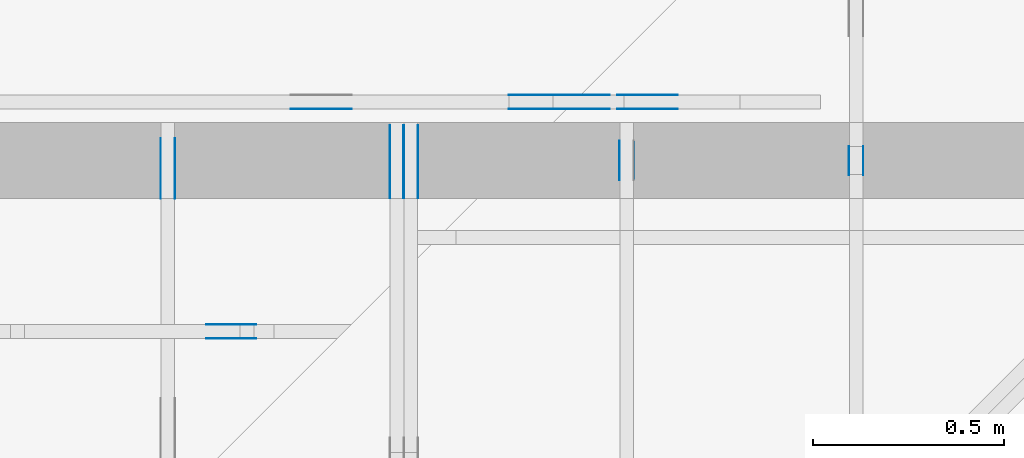
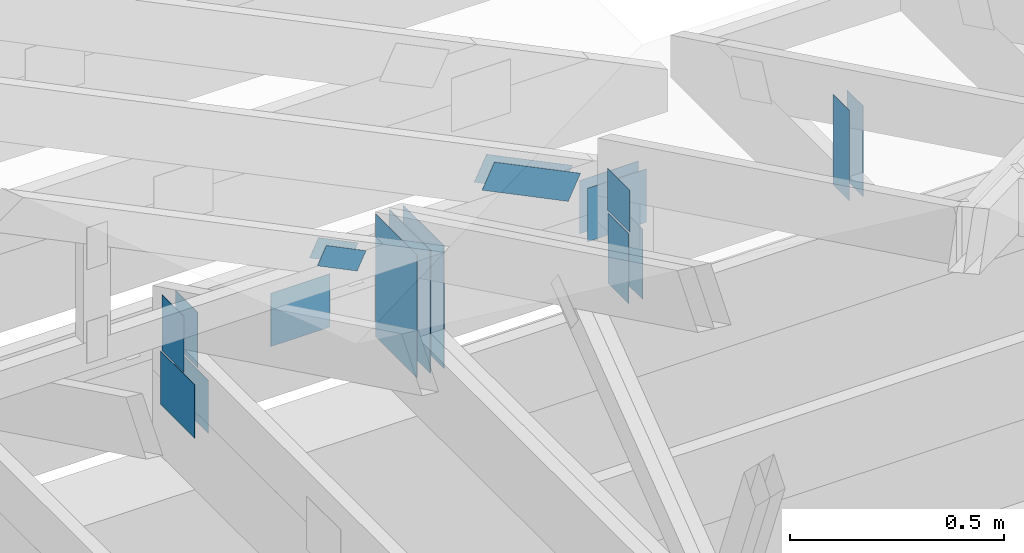
# One storey, part 131 of 159: 20 plates, 6 elements without a shape of their own.
"""IFC2X3 building model written with IfcOpenShell, lengths in millimetres."""

from ifc_helpers import new_model, si_unit, frame, origin, origin_with_axes, origin_2d, place, context, project, spatial, faceted_brep, element, aggregate, save


model = new_model("IFC2X3")

# Units and contexts
model_context = context("Model", 3, precision=1e-05, world=origin())
plan_context = context("Plan", 2, precision=1e-05, world=origin_2d())
ifc_project = project(units=[si_unit("LENGTHUNIT", "METRE", prefix="MILLI"), si_unit("AREAUNIT", "SQUARE_METRE"), si_unit("VOLUMEUNIT", "CUBIC_METRE"), si_unit("SOLIDANGLEUNIT", "STERADIAN"), si_unit("PLANEANGLEUNIT", "RADIAN"), si_unit("MASSUNIT", "GRAM"), si_unit("TIMEUNIT", "SECOND"), si_unit("THERMODYNAMICTEMPERATUREUNIT", "DEGREE_CELSIUS"), si_unit("LUMINOUSINTENSITYUNIT", "LUMEN")], contexts=[model_context, plan_context])

# Site, building, storey
site_placement = place(None, origin_with_axes())
site = spatial("IfcSite", under=ifc_project, at=site_placement, CompositionType="ELEMENT")
building_placement = place(site_placement, origin_with_axes())
building = spatial("IfcBuilding", under=site, at=building_placement, Name="Plan 1", CompositionType="ELEMENT")
storey_placement = place(building_placement, origin_with_axes())
storey = spatial("IfcBuildingStorey", under=building, at=storey_placement, Name="Etasje 1", CompositionType="ELEMENT", Elevation=0.0)

# Assembly, plates
assembly_1_placement = place(storey_placement, frame((10000.012663278096, 9072.000080051337, 1.1021457184401395e-15), z_axis=(9.811600543477555e-09, 1.0, 6.123031769111886e-17), x_axis=(-1.0, 9.811600543477555e-09, 0.0)))
assembly_1 = element("IfcElementAssembly", 1, at=assembly_1_placement, inside=storey, Name="T9 (79)", AssemblyPlace="FACTORY", PredefinedType="TRUSS")
plate_1_placement = place(assembly_1_placement, frame((-8826.91796875, 147.0, 0.0), z_axis=(0.0, 0.0, 1.0), x_axis=(1.0, 0.0, 0.0)))
plate_1 = element("IfcPlate", 2, at=plate_1_placement, Name="GNT100S 152x159", context=model_context, shape_type="Brep", body=[
    faceted_brep([(159.0, 152.0, 1.0), (0.0, 152.0, 1.0), (0.0, 0.0, 1.0), (159.0, 0.0, 1.0), (0.0, 152.0, 0.0), (159.0, 152.0, 1.9471241025775798e-14), (159.0, 0.0, 1.9471241025775798e-14), (0.0, 0.0, 0.0), (159.00041615731425, -2.920693798299738e-14, 1.788350091483736e-30), (159.00041615731425, -2.9145707665306264e-14, 1.0), (0.00041615731424826663, 6.115387335743615e-17, 1.0), (0.00041615731424826663, -7.644433368271246e-20, 4.680710837078382e-36), (159.00041615731425, 152.0, 0.0), (159.00041615731425, 152.0, 1.0), (159.00041615731425, 0.0, 1.0), (159.00041615731425, 0.0, 0.0), (0.00041615731424826663, 152.0, 0.0), (0.00041615731424826663, 152.0, 1.0), (159.00041615731425, 152.0, 1.0), (159.00041615731425, 152.0, 0.0), (0.00041615731424826663, 0.0, 0.0), (0.0004161573142483279, -7.498303609110687e-33, 1.0), (0.0004161573142669419, 152.0, 1.0), (0.00041615731426688065, 152.0, -1.1397412669640613e-30)], [[[0, 1, 2, 3]], [[4, 5, 6, 7]], [[8, 9, 10, 11]], [[12, 13, 14, 15]], [[16, 17, 18, 19]], [[20, 21, 22, 23]]]),
])
plate_2_placement = place(assembly_1_placement, frame((-8826.91796875, 147.0, -37.0), z_axis=(0.0, 0.0, 1.0), x_axis=(1.0, 0.0, 0.0)))
plate_2 = element("IfcPlate", 3, at=plate_2_placement, Name="GNT100S 152x159", context=model_context, shape_type="Brep", body=[
    faceted_brep([(159.0, 152.0, 1.0), (0.0, 152.0, 1.0), (0.0, 0.0, 1.0), (159.0, 0.0, 1.0), (0.0, 152.0, 0.0), (159.0, 152.0, 1.9471241025775798e-14), (159.0, 0.0, 1.9471241025775798e-14), (0.0, 0.0, 0.0), (159.00041615731425, -2.920693798299738e-14, 1.788350091483736e-30), (159.00041615731425, -2.9145707665306264e-14, 1.0), (0.00041615731424826663, 6.115387335743615e-17, 1.0), (0.00041615731424826663, -7.644433368271246e-20, 4.680710837078382e-36), (159.00041615731425, 152.0, 0.0), (159.00041615731425, 152.0, 1.0), (159.00041615731425, 0.0, 1.0), (159.00041615731425, 0.0, 0.0), (0.00041615731424826663, 152.0, 0.0), (0.00041615731424826663, 152.0, 1.0), (159.00041615731425, 152.0, 1.0), (159.00041615731425, 152.0, 0.0), (0.00041615731424826663, 0.0, 0.0), (0.0004161573142483279, -7.498303609110687e-33, 1.0), (0.0004161573142669419, 152.0, 1.0), (0.00041615731426688065, 152.0, -1.1397412669640613e-30)], [[[0, 1, 2, 3]], [[4, 5, 6, 7]], [[8, 9, 10, 11]], [[12, 13, 14, 15]], [[16, 17, 18, 19]], [[20, 21, 22, 23]]]),
])
plate_3_placement = place(assembly_1_placement, frame((-7973.47314453125, 147.0, -37.0), z_axis=(0.0, 0.0, 1.0), x_axis=(1.0, 0.0, 0.0)))
plate_3 = element("IfcPlate", 4, at=plate_3_placement, Name="GNT100S 152x159", context=model_context, shape_type="Brep", body=[
    faceted_brep([(159.0, 152.0, 1.0), (0.0, 152.0, 1.0), (0.0, 0.0, 1.0), (159.0, 0.0, 1.0), (0.0, 152.0, 0.0), (159.0, 152.0, 1.9471241025775798e-14), (159.0, 0.0, 1.9471241025775798e-14), (0.0, 0.0, 0.0), (159.00006797736023, -2.9206874025489785e-14, 1.7883461753452272e-30), (159.00006797736023, -2.9145643707798666e-14, 1.0), (6.797736023145262e-05, 6.121783086503054e-17, 1.0), (6.797736023145262e-05, -1.248682608832642e-20, 7.645723283419777e-37), (159.00006797736023, 152.0, 0.0), (159.00006797736023, 152.0, 1.0), (159.00006797736023, 0.0, 1.0), (159.00006797736023, 0.0, 0.0), (6.797736023145262e-05, 152.0, 0.0), (6.797736023145262e-05, 152.0, 1.0), (159.00006797736023, 152.0, 1.0), (159.00006797736023, 152.0, 0.0), (6.797736023145262e-05, 0.0, 0.0), (6.797736023151385e-05, -7.498303609110687e-33, 1.0), (6.797736025012787e-05, 152.0, 1.0), (6.797736025006664e-05, 152.0, -1.1397420192804459e-30)], [[[0, 1, 2, 3]], [[4, 5, 6, 7]], [[8, 9, 10, 11]], [[12, 13, 14, 15]], [[16, 17, 18, 19]], [[20, 21, 22, 23]]]),
])
plate_4_placement = place(assembly_1_placement, frame((-8615.85361649331, 280.2957601707253, 0.0), z_axis=(0.0, 0.0, 1.0), x_axis=(0.8987940462991671, 0.438371146789077, 0.0)))
plate_4 = element("IfcPlate", 5, at=plate_4_placement, Name="GNT100S 76x258", context=model_context, shape_type="Brep", body=[
    faceted_brep([(258.0006943892495, 76.00022406976359, 1.0), (0.0, 76.00022406976359, 1.0), (0.00017802805359679041, 0.00013491363233697484, 1.0), (257.99999468874194, 0.00013491363233697484, 1.0), (0.0, 76.00022406976359, 0.0), (258.0006943892495, 76.00022406976359, 3.1594928963966024e-14), (257.99999468874194, 0.00019715747384907445, 3.1594843278197295e-14), (0.00017802805359679041, 0.00019715747384907445, 2.1801428559326026e-20), (258.0004291662817, -5.094506431539717e-14, 3.119382472826252e-30), (258.0004291662817, -5.0883833997706053e-14, 1.0), (0.00042916628262901213, 4.548084964604827e-13, 1.0), (0.00042916628262901213, 4.5474726614279163e-13, 5.188881990034325e-36), (258.0004291662817, 76.00000000000045, -5.679798517591285e-29), (258.0004291662817, 76.00000000000045, 1.0), (258.0004291662817, 0.0, 1.0), (258.0004291662817, 0.0, 0.0), (0.00042916628262901213, 75.99999999999955, 0.0), (0.00042916628262901213, 75.99999999999955, 1.0), (258.00042916628263, 76.00000000000044, 1.0), (258.00042916628263, 76.00000000000044, 0.0), (0.00042916628262901213, 4.547473508864641e-13, 0.0), (0.0004291662826290734, 4.547473508864641e-13, 1.0), (0.00042916628263838034, 75.99999999999955, 1.0), (0.00042916628263831914, 75.99999999999955, -5.698706334820307e-31)], [[[0, 1, 2, 3]], [[4, 5, 6, 7]], [[8, 9, 10, 11]], [[12, 13, 14, 15]], [[16, 17, 18, 19]], [[20, 21, 22, 23]]]),
])
plate_5_placement = place(assembly_1_placement, frame((-8615.85361649331, 280.2957601707253, -36.99999999999999), z_axis=(0.0, 0.0, 1.0), x_axis=(0.8987940462991671, 0.438371146789077, 0.0)))
plate_5 = element("IfcPlate", 6, at=plate_5_placement, Name="GNT100S 76x258", context=model_context, shape_type="Brep", body=[
    faceted_brep([(258.0006943892495, 76.00022406976359, 1.0), (0.0, 76.00022406976359, 1.0), (0.00017802805359679041, 0.00013491363233697484, 1.0), (257.99999468874194, 0.00013491363233697484, 1.0), (0.0, 76.00022406976359, 0.0), (258.0006943892495, 76.00022406976359, 3.1594928963966024e-14), (257.99999468874194, 0.00019715747384907445, 3.1594843278197295e-14), (0.00017802805359679041, 0.00019715747384907445, 2.1801428559326026e-20), (258.0004291662817, -5.094506431539717e-14, 3.119382472826252e-30), (258.0004291662817, -5.0883833997706053e-14, 1.0), (0.00042916628262901213, 4.548084964604827e-13, 1.0), (0.00042916628262901213, 4.5474726614279163e-13, 5.188881990034325e-36), (258.0004291662817, 76.00000000000045, -5.679798517591285e-29), (258.0004291662817, 76.00000000000045, 1.0), (258.0004291662817, 0.0, 1.0), (258.0004291662817, 0.0, 0.0), (0.00042916628262901213, 75.99999999999955, 0.0), (0.00042916628262901213, 75.99999999999955, 1.0), (258.00042916628263, 76.00000000000044, 1.0), (258.00042916628263, 76.00000000000044, 0.0), (0.00042916628262901213, 4.547473508864641e-13, 0.0), (0.0004291662826290734, 4.547473508864641e-13, 1.0), (0.00042916628263838034, 75.99999999999955, 1.0), (0.00042916628263831914, 75.99999999999955, -5.698706334820307e-31)], [[[0, 1, 2, 3]], [[4, 5, 6, 7]], [[8, 9, 10, 11]], [[12, 13, 14, 15]], [[16, 17, 18, 19]], [[20, 21, 22, 23]]]),
])
aggregate(assembly_1, [plate_1, plate_2, plate_3, plate_4, plate_5])

assembly_2_placement = place(storey_placement, frame((18074.541652722903, -699.9989301294845, 4.408582873760558e-15), z_axis=(-1.0, 1.836909530733566e-16, 6.123031769111886e-17), x_axis=(-1.836909530733566e-16, -1.0, 0.0)))
assembly_2 = element("IfcElementAssembly", 7, at=assembly_2_placement, inside=storey, Name="V5 (30)", AssemblyPlace="FACTORY", PredefinedType="TRUSS")
plate_6_placement = place(assembly_2_placement, frame((-9501.99892397318, 109.01662445068358, 0.0), z_axis=(0.0, 0.0, 1.0), x_axis=(6.123031769111886e-17, 1.0, 0.0)))
plate_6 = element("IfcPlate", 8, at=plate_6_placement, context=model_context, shape_type="Brep", body=[
    faceted_brep([(350.00000762939453, 192.00009946431965, 1.3), (0.0, 192.00009946431965, 1.3), (1.4210854715202004e-14, 9.946431964635849e-05, 1.3), (350.00000762939453, 9.946431964635849e-05, 1.3), (0.0, 192.00009946431965, 0.0), (350.00000762939453, 192.00009946431965, 4.2861223318083706e-14), (350.00000762939453, 9.946431964635849e-05, 4.2861223318083706e-14), (1.4210854715202004e-14, 9.946431964635849e-05, 1.7402702977483063e-30), (350.0000025879075, -6.429183405105e-14, 3.936609423890485e-30), (350.0000025879075, -6.421223463805154e-14, 1.3), (2.5879074883050635e-06, 7.959893762326153e-17, 1.3), (2.5879074883050635e-06, -4.753751929924335e-22, 2.9107374089403646e-38), (350.0000025879075, 192.0, 0.0), (350.0000025879075, 192.0, 1.3), (350.0000025879075, 0.0, 1.3), (350.0000025879075, 0.0, 0.0), (2.5879074883050635e-06, 192.0, 0.0), (2.5879074883050635e-06, 192.0, 1.3), (350.0000025879075, 191.99999999999997, 1.3), (350.0000025879075, 191.99999999999997, -1.5777218104420236e-30), (2.5879074883050635e-06, 0.0, 0.0), (2.587907488384663e-06, -9.747794691843893e-33, 1.3), (2.587907511897105e-06, 192.0, 1.3), (2.5879075118175054e-06, 192.0, -1.439674292949252e-30)], [[[0, 1, 2, 3]], [[4, 5, 6, 7]], [[8, 9, 10, 11]], [[12, 13, 14, 15]], [[16, 17, 18, 19]], [[20, 21, 22, 23]]]),
])
plate_7_placement = place(assembly_2_placement, frame((-9501.99892397318, 109.01662445068358, -37.3), z_axis=(0.0, 0.0, 1.0), x_axis=(6.123031769111886e-17, 1.0, 0.0)))
plate_7 = element("IfcPlate", 9, at=plate_7_placement, context=model_context, shape_type="Brep", body=[
    faceted_brep([(350.00000762939453, 192.00009946431965, 1.2999999999999972), (0.0, 192.00009946431965, 1.2999999999999972), (1.4210854715202004e-14, 9.946431964635849e-05, 1.2999999999999972), (350.00000762939453, 9.946431964635849e-05, 1.2999999999999972), (0.0, 192.00009946431965, 0.0), (350.00000762939453, 192.00009946431965, 4.2861223318083706e-14), (350.00000762939453, 9.946431964635849e-05, 4.2861223318083706e-14), (1.4210854715202004e-14, 9.946431964635849e-05, 1.7402702977483063e-30), (350.0000025879075, -6.429183405105e-14, 3.936609423890485e-30), (350.0000025879075, -6.421223463805154e-14, 1.2999999999999972), (2.5879074883050635e-06, 7.959893762326135e-17, 1.2999999999999972), (2.5879074883050635e-06, -4.753751929924335e-22, 2.9107374089403646e-38), (350.0000025879075, 192.0, 0.0), (350.0000025879075, 192.0, 1.2999999999999972), (350.0000025879075, 0.0, 1.2999999999999972), (350.0000025879075, 0.0, 0.0), (2.5879074883050635e-06, 192.0, 0.0), (2.5879074883050635e-06, 192.0, 1.2999999999999972), (350.0000025879075, 191.99999999999997, 1.2999999999999972), (350.0000025879075, 191.99999999999997, -1.5777218104420236e-30), (2.5879074883050635e-06, 0.0, 0.0), (2.587907488384663e-06, -9.747794691843873e-33, 1.2999999999999972), (2.587907511897105e-06, 192.0, 1.2999999999999972), (2.5879075118175054e-06, 192.0, -1.439674292949252e-30)], [[[0, 1, 2, 3]], [[4, 5, 6, 7]], [[8, 9, 10, 11]], [[12, 13, 14, 15]], [[16, 17, 18, 19]], [[20, 21, 22, 23]]]),
])
plate_8_placement = place(assembly_2_placement, frame((-9501.99892397318, 109.01662445068358, -36.0), z_axis=(0.0, 0.0, 1.0), x_axis=(6.123031769111886e-17, 1.0, 0.0)))
plate_8 = element("IfcPlate", 10, at=plate_8_placement, context=model_context, shape_type="Brep", body=[
    faceted_brep([(350.00000762939453, 192.00009946431965, 1.2999999999999972), (0.0, 192.00009946431965, 1.2999999999999972), (1.4210854715202004e-14, 9.946431964635849e-05, 1.2999999999999972), (350.00000762939453, 9.946431964635849e-05, 1.2999999999999972), (0.0, 192.00009946431965, 0.0), (350.00000762939453, 192.00009946431965, 4.2861223318083706e-14), (350.00000762939453, 9.946431964635849e-05, 4.2861223318083706e-14), (1.4210854715202004e-14, 9.946431964635849e-05, 1.7402702977483063e-30), (350.0000025879075, -6.429183405105e-14, 3.936609423890485e-30), (350.0000025879075, -6.421223463805154e-14, 1.2999999999999972), (2.5879074883050635e-06, 7.959893762326135e-17, 1.2999999999999972), (2.5879074883050635e-06, -4.753751929924335e-22, 2.9107374089403646e-38), (350.0000025879075, 192.0, 0.0), (350.0000025879075, 192.0, 1.2999999999999972), (350.0000025879075, 0.0, 1.2999999999999972), (350.0000025879075, 0.0, 0.0), (2.5879074883050635e-06, 192.0, 0.0), (2.5879074883050635e-06, 192.0, 1.2999999999999972), (350.0000025879075, 191.99999999999997, 1.2999999999999972), (350.0000025879075, 191.99999999999997, -1.5777218104420236e-30), (2.5879074883050635e-06, 0.0, 0.0), (2.587907488384663e-06, -9.747794691843873e-33, 1.2999999999999972), (2.587907511897105e-06, 192.0, 1.2999999999999972), (2.5879075118175054e-06, 192.0, -1.439674292949252e-30)], [[[0, 1, 2, 3]], [[4, 5, 6, 7]], [[8, 9, 10, 11]], [[12, 13, 14, 15]], [[16, 17, 18, 19]], [[20, 21, 22, 23]]]),
])
plate_9_placement = place(assembly_2_placement, frame((-9501.99892397318, 109.01662445068358, -73.3), z_axis=(0.0, 0.0, 1.0), x_axis=(6.123031769111886e-17, 1.0, 0.0)))
plate_9 = element("IfcPlate", 11, at=plate_9_placement, context=model_context, shape_type="Brep", body=[
    faceted_brep([(350.00000762939453, 192.00009946431965, 1.2999999999999972), (0.0, 192.00009946431965, 1.2999999999999972), (1.4210854715202004e-14, 9.946431964635849e-05, 1.2999999999999972), (350.00000762939453, 9.946431964635849e-05, 1.2999999999999972), (0.0, 192.00009946431965, 0.0), (350.00000762939453, 192.00009946431965, 4.2861223318083706e-14), (350.00000762939453, 9.946431964635849e-05, 4.2861223318083706e-14), (1.4210854715202004e-14, 9.946431964635849e-05, 1.7402702977483063e-30), (350.0000025879075, -6.429183405105e-14, 3.936609423890485e-30), (350.0000025879075, -6.421223463805154e-14, 1.2999999999999972), (2.5879074883050635e-06, 7.959893762326135e-17, 1.2999999999999972), (2.5879074883050635e-06, -4.753751929924335e-22, 2.9107374089403646e-38), (350.0000025879075, 192.0, 0.0), (350.0000025879075, 192.0, 1.2999999999999972), (350.0000025879075, 0.0, 1.2999999999999972), (350.0000025879075, 0.0, 0.0), (2.5879074883050635e-06, 192.0, 0.0), (2.5879074883050635e-06, 192.0, 1.2999999999999972), (350.0000025879075, 191.99999999999997, 1.2999999999999972), (350.0000025879075, 191.99999999999997, -1.5777218104420236e-30), (2.5879074883050635e-06, 0.0, 0.0), (2.587907488384663e-06, -9.747794691843873e-33, 1.2999999999999972), (2.587907511897105e-06, 192.0, 1.2999999999999972), (2.5879075118175054e-06, 192.0, -1.439674292949252e-30)], [[[0, 1, 2, 3]], [[4, 5, 6, 7]], [[8, 9, 10, 11]], [[12, 13, 14, 15]], [[16, 17, 18, 19]], [[20, 21, 22, 23]]]),
])
aggregate(assembly_2, [plate_6, plate_7, plate_8, plate_9])

assembly_3_placement = place(storey_placement, frame((17475.02226140475, -699.9989301294827, 1.1021457184401395e-15), z_axis=(-1.0, 1.836909530733566e-16, 6.123031769111886e-17), x_axis=(-1.836909530733566e-16, -1.0, 0.0)))
assembly_3 = element("IfcElementAssembly", 12, at=assembly_3_placement, inside=storey, Name="V6 (31)", AssemblyPlace="FACTORY", PredefinedType="TRUSS")
plate_10_placement = place(assembly_3_placement, frame((-9551.357421875, 304.17950439453125, 0.0), z_axis=(0.0, 0.0, 1.0), x_axis=(6.123031769111886e-17, 1.0, 0.0)))
plate_10 = element("IfcPlate", 13, at=plate_10_placement, Name="GNT100S 103x159", context=model_context, shape_type="Brep", body=[
    faceted_brep([(159.0, 103.0, 1.0), (0.0, 103.0, 1.0), (0.0, 0.0, 1.0), (159.0, 0.0, 1.0), (0.0, 103.0, 0.0), (159.0, 103.0, 1.9471241025775798e-14), (159.0, 0.0, 1.9471241025775798e-14), (0.0, 0.0, 0.0), (159.0, 0.00015826327032108267, 1.7883448193523036e-30), (159.0, 0.0001582632703211439, 1.0), (1.1247455413666031e-32, 0.00015826327035035076, 1.0), (0.0, 0.00015826327035028953, 0.0), (159.0, 103.00015826327035, 0.0), (159.0, 103.00015826327035, 1.0), (159.0, 0.00015826327035028953, 1.0), (159.0, 0.00015826327035028953, 0.0), (0.0, 103.00015826327035, 0.0), (-3.7491518045553436e-33, 103.00015826327035, 1.0), (159.0, 103.00015826327034, 1.0), (159.0, 103.00015826327034, -7.888609052210118e-31), (1.938102064476732e-20, 0.00015826327035028953, -1.1867060512572364e-36), (6.124969871176363e-17, 0.00015826327035028953, 1.0), (1.267469514308225e-14, 103.00015826327035, 1.0), (1.2613464825391131e-14, 103.00015826327035, -7.723264584444521e-31)], [[[0, 1, 2, 3]], [[4, 5, 6, 7]], [[8, 9, 10, 11]], [[12, 13, 14, 15]], [[16, 17, 18, 19]], [[20, 21, 22, 23]]]),
])
plate_11_placement = place(assembly_3_placement, frame((-9551.357421875, 304.17950439453125, -37.0), z_axis=(0.0, 0.0, 1.0), x_axis=(6.123031769111886e-17, 1.0, 0.0)))
plate_11 = element("IfcPlate", 14, at=plate_11_placement, Name="GNT100S 103x159", context=model_context, shape_type="Brep", body=[
    faceted_brep([(159.0, 103.0, 1.0), (0.0, 103.0, 1.0), (0.0, 0.0, 1.0), (159.0, 0.0, 1.0), (0.0, 103.0, 0.0), (159.0, 103.0, 1.9471241025775798e-14), (159.0, 0.0, 1.9471241025775798e-14), (0.0, 0.0, 0.0), (159.0, 0.00015826327032108267, 1.7883448193523036e-30), (159.0, 0.0001582632703211439, 1.0), (1.1247455413666031e-32, 0.00015826327035035076, 1.0), (0.0, 0.00015826327035028953, 0.0), (159.0, 103.00015826327035, 0.0), (159.0, 103.00015826327035, 1.0), (159.0, 0.00015826327035028953, 1.0), (159.0, 0.00015826327035028953, 0.0), (0.0, 103.00015826327035, 0.0), (-3.7491518045553436e-33, 103.00015826327035, 1.0), (159.0, 103.00015826327034, 1.0), (159.0, 103.00015826327034, -7.888609052210118e-31), (1.938102064476732e-20, 0.00015826327035028953, -1.1867060512572364e-36), (6.124969871176363e-17, 0.00015826327035028953, 1.0), (1.267469514308225e-14, 103.00015826327035, 1.0), (1.2613464825391131e-14, 103.00015826327035, -7.723264584444521e-31)], [[[0, 1, 2, 3]], [[4, 5, 6, 7]], [[8, 9, 10, 11]], [[12, 13, 14, 15]], [[16, 17, 18, 19]], [[20, 21, 22, 23]]]),
])
plate_12_placement = place(assembly_3_placement, frame((-9659.9990234375, 147.0, 0.0), z_axis=(0.0, 0.0, 1.0), x_axis=(1.0, 0.0, 0.0)))
plate_12 = element("IfcPlate", 15, at=plate_12_placement, Name="GNT100S 152x159", context=model_context, shape_type="Brep", body=[
    faceted_brep([(159.0, 152.0, 1.0), (0.0, 152.0, 1.0), (0.0, 0.0, 1.0), (159.0, 0.0, 1.0), (0.0, 152.0, 0.0), (159.0, 152.0, 1.9471241025775798e-14), (159.0, 0.0, 1.9471241025775798e-14), (0.0, 0.0, 0.0), (159.00009946362115, 1.69745086203597e-13, 1.788346529485543e-30), (159.00009946362115, 1.6980631652128811e-13, 1.0), (9.946362115442753e-05, 1.990131780599518e-13, 1.0), (9.946362115442753e-05, 1.989519477422607e-13, 1.1187126440350437e-36), (159.00009946362115, 152.00000000000023, 0.0), (159.00009946362115, 152.00000000000023, 1.0), (159.00009946362115, 1.9895196601282805e-13, 1.0), (159.00009946362115, 1.9895196601282805e-13, 0.0), (9.946362115442753e-05, 152.00000000000023, 0.0), (9.946362115442753e-05, 152.00000000000023, 1.0), (159.00009946362115, 152.00000000000023, 1.0), (159.00009946362115, 152.00000000000023, 0.0), (9.946362115442753e-05, 1.9895196601282805e-13, 0.0), (9.946362115448876e-05, 1.9895196601282805e-13, 1.0), (9.946362117310278e-05, 152.00000000000023, 1.0), (9.946362117304154e-05, 152.00000000000023, -1.1397420192804459e-30)], [[[0, 1, 2, 3]], [[4, 5, 6, 7]], [[8, 9, 10, 11]], [[12, 13, 14, 15]], [[16, 17, 18, 19]], [[20, 21, 22, 23]]]),
])
plate_13_placement = place(assembly_3_placement, frame((-9659.9990234375, 147.0, -37.0), z_axis=(0.0, 0.0, 1.0), x_axis=(1.0, 0.0, 0.0)))
plate_13 = element("IfcPlate", 16, at=plate_13_placement, Name="GNT100S 152x159", context=model_context, shape_type="Brep", body=[
    faceted_brep([(159.0, 152.0, 1.0), (0.0, 152.0, 1.0), (0.0, 0.0, 1.0), (159.0, 0.0, 1.0), (0.0, 152.0, 0.0), (159.0, 152.0, 1.9471241025775798e-14), (159.0, 0.0, 1.9471241025775798e-14), (0.0, 0.0, 0.0), (159.00009946362115, 1.69745086203597e-13, 1.788346529485543e-30), (159.00009946362115, 1.6980631652128811e-13, 1.0), (9.946362115442753e-05, 1.990131780599518e-13, 1.0), (9.946362115442753e-05, 1.989519477422607e-13, 1.1187126440350437e-36), (159.00009946362115, 152.00000000000023, 0.0), (159.00009946362115, 152.00000000000023, 1.0), (159.00009946362115, 1.9895196601282805e-13, 1.0), (159.00009946362115, 1.9895196601282805e-13, 0.0), (9.946362115442753e-05, 152.00000000000023, 0.0), (9.946362115442753e-05, 152.00000000000023, 1.0), (159.00009946362115, 152.00000000000023, 1.0), (159.00009946362115, 152.00000000000023, 0.0), (9.946362115442753e-05, 1.9895196601282805e-13, 0.0), (9.946362115448876e-05, 1.9895196601282805e-13, 1.0), (9.946362117310278e-05, 152.00000000000023, 1.0), (9.946362117304154e-05, 152.00000000000023, -1.1397420192804459e-30)], [[[0, 1, 2, 3]], [[4, 5, 6, 7]], [[8, 9, 10, 11]], [[12, 13, 14, 15]], [[16, 17, 18, 19]], [[20, 21, 22, 23]]]),
])
aggregate(assembly_3, [plate_10, plate_11, plate_12, plate_13])

assembly_4_placement = place(storey_placement, frame((19275.02226140475, 9699.999999999993, 1.1021457184401395e-15), z_axis=(-1.0, 1.836909530733566e-16, 6.123031769111886e-17), x_axis=(-1.836909530733566e-16, -1.0, 0.0)))
assembly_4 = element("IfcElementAssembly", 17, at=assembly_4_placement, inside=storey, Name="S23 (56)", AssemblyPlace="FACTORY", PredefinedType="TRUSS")
plate_14_placement = place(assembly_4_placement, frame((761.0, 413.0166320800781, 0.0), z_axis=(0.0, 0.0, 1.0), x_axis=(6.123031769111886e-17, -1.0, 0.0)))
plate_14 = element("IfcPlate", 18, at=plate_14_placement, Name="GNT100S 76x258", context=model_context, shape_type="Brep", body=[
    faceted_brep([(258.0, 76.0, 1.0), (0.0, 76.0, 1.0), (0.0, 0.0, 1.0), (258.0, 0.0, 1.0), (0.0, 76.0, 0.0), (258.0, 76.0, 3.1594843928617333e-14), (258.0, 0.0, 3.1594843928617333e-14), (0.0, 0.0, 0.0), (258.0000065434458, -4.73922670948978e-14, 2.901843570322951e-30), (258.0000065434458, -4.733103677720668e-14, 1.0), (6.543445806528325e-06, 6.122911571932227e-17, 1.0), (6.543445806528325e-06, -1.2019717965850465e-21, 7.35971149606673e-38), (258.0000065434458, 76.0, 0.0), (258.0000065434458, 76.0, 1.0), (258.0000065434458, 0.0, 1.0), (258.0000065434458, 0.0, 0.0), (6.543445806528325e-06, 76.0, 0.0), (6.543445806528325e-06, 76.0, 1.0), (258.0000065434458, 75.99999999999999, 1.0), (258.0000065434458, 75.99999999999999, -7.888609052210118e-31), (6.543445806528325e-06, 0.0, 0.0), (6.5434458065895555e-06, -7.498303609110687e-33, 1.0), (6.543445815896564e-06, 76.0, 1.0), (6.5434458158353335e-06, 76.0, -5.69871056659997e-31)], [[[0, 1, 2, 3]], [[4, 5, 6, 7]], [[8, 9, 10, 11]], [[12, 13, 14, 15]], [[16, 17, 18, 19]], [[20, 21, 22, 23]]]),
])
plate_15_placement = place(assembly_4_placement, frame((761.0, 413.0166320800781, -37.0), z_axis=(0.0, 0.0, 1.0), x_axis=(6.123031769111886e-17, -1.0, 0.0)))
plate_15 = element("IfcPlate", 19, at=plate_15_placement, Name="GNT100S 76x258", context=model_context, shape_type="Brep", body=[
    faceted_brep([(258.0, 76.0, 1.0), (0.0, 76.0, 1.0), (0.0, 0.0, 1.0), (258.0, 0.0, 1.0), (0.0, 76.0, 0.0), (258.0, 76.0, 3.1594843928617333e-14), (258.0, 0.0, 3.1594843928617333e-14), (0.0, 0.0, 0.0), (258.0000065434458, -4.73922670948978e-14, 2.901843570322951e-30), (258.0000065434458, -4.733103677720668e-14, 1.0), (6.543445806528325e-06, 6.122911571932227e-17, 1.0), (6.543445806528325e-06, -1.2019717965850465e-21, 7.35971149606673e-38), (258.0000065434458, 76.0, 0.0), (258.0000065434458, 76.0, 1.0), (258.0000065434458, 0.0, 1.0), (258.0000065434458, 0.0, 0.0), (6.543445806528325e-06, 76.0, 0.0), (6.543445806528325e-06, 76.0, 1.0), (258.0000065434458, 75.99999999999999, 1.0), (258.0000065434458, 75.99999999999999, -7.888609052210118e-31), (6.543445806528325e-06, 0.0, 0.0), (6.5434458065895555e-06, -7.498303609110687e-33, 1.0), (6.543445815896564e-06, 76.0, 1.0), (6.5434458158353335e-06, 76.0, -5.69871056659997e-31)], [[[0, 1, 2, 3]], [[4, 5, 6, 7]], [[8, 9, 10, 11]], [[12, 13, 14, 15]], [[16, 17, 18, 19]], [[20, 21, 22, 23]]]),
])
aggregate(assembly_4, [plate_14, plate_15])

assembly_5_placement = place(storey_placement, frame((18675.02226140475, 8999.999999999993, 1.1021457184401395e-15), z_axis=(-1.0, 1.836909530733566e-16, 6.123031769111886e-17), x_axis=(-1.836909530733566e-16, -1.0, 0.0)))
assembly_5 = element("IfcElementAssembly", 20, at=assembly_5_placement, inside=storey, Name="S25 (55)", AssemblyPlace="FACTORY", PredefinedType="TRUSS")
plate_16_placement = place(assembly_5_placement, frame((147.00000000186265, 77.99999999999999, 0.0), z_axis=(0.0, 0.0, 1.0), x_axis=(6.123031769111886e-17, 1.0, 0.0)))
plate_16 = element("IfcPlate", 21, at=plate_16_placement, context=model_context, shape_type="Brep", body=[
    faceted_brep([(200.0, 96.00000000186265, 1.3), (0.0, 96.00000000186265, 1.3), (1.4210854715202004e-14, 1.862645149230957e-09, 1.3), (200.0, 1.862645149230957e-09, 1.3), (0.0, 96.00000000186265, 0.0), (200.0, 96.00000000186265, 2.4492127076447545e-14), (200.0, 1.8626735709403874e-09, 2.4492127076447545e-14), (1.4210854715202004e-14, 1.8626735709403874e-09, 1.7402702977483063e-30), (200.0, -3.6738190614671324e-14, 3.989761380481513e-30), (200.0, -3.665859120167287e-14, 1.3), (4.263256414560601e-14, 7.959941299844064e-17, 1.3), (4.263256414560601e-14, -1.3889668091964752e-29, 8.504687898951986e-46), (200.0, 96.00000000000001, 0.0), (200.0, 96.00000000000001, 1.3), (200.0, 2.842170943040401e-14, 1.3), (200.0, 2.842170943040401e-14, 0.0), (2.842170943040401e-14, 96.0, 0.0), (2.842170943040401e-14, 96.0, 1.3), (200.00000000000003, 96.00000000000003, 1.3), (200.00000000000003, 96.00000000000003, 7.888609052210118e-31), (4.263256414560601e-14, 0.0, 0.0), (4.2712163558604464e-14, -9.747794691844174e-33, 1.3), (5.4468384555299286e-14, 96.0, 1.3), (5.438878514230083e-14, 96.0, -1.589972295348779e-30)], [[[0, 1, 2, 3]], [[4, 5, 6, 7]], [[8, 9, 10, 11]], [[12, 13, 14, 15]], [[16, 17, 18, 19]], [[20, 21, 22, 23]]]),
])
plate_17_placement = place(assembly_5_placement, frame((147.00000000186265, 77.99999999999999, -37.3), z_axis=(0.0, 0.0, 1.0), x_axis=(6.123031769111886e-17, 1.0, 0.0)))
plate_17 = element("IfcPlate", 22, at=plate_17_placement, context=model_context, shape_type="Brep", body=[
    faceted_brep([(200.0, 96.00000000186265, 1.2999999999999972), (0.0, 96.00000000186265, 1.2999999999999972), (1.4210854715202004e-14, 1.862645149230957e-09, 1.2999999999999972), (200.0, 1.862645149230957e-09, 1.2999999999999972), (0.0, 96.00000000186265, 0.0), (200.0, 96.00000000186265, 2.4492127076447545e-14), (200.0, 1.8626735709403874e-09, 2.4492127076447545e-14), (1.4210854715202004e-14, 1.8626735709403874e-09, 1.7402702977483063e-30), (200.0, -3.6738190614671324e-14, 3.989761380481513e-30), (200.0, -3.665859120167287e-14, 1.2999999999999972), (4.263256414560601e-14, 7.959941299844045e-17, 1.2999999999999972), (4.263256414560601e-14, -1.3889668091964752e-29, 8.504687898951986e-46), (200.0, 96.00000000000001, 0.0), (200.0, 96.00000000000001, 1.2999999999999972), (200.0, 2.842170943040401e-14, 1.2999999999999972), (200.0, 2.842170943040401e-14, 0.0), (2.842170943040401e-14, 96.0, 0.0), (2.842170943040401e-14, 96.0, 1.2999999999999972), (200.00000000000003, 96.00000000000003, 1.2999999999999972), (200.00000000000003, 96.00000000000003, 7.888609052210118e-31), (4.263256414560601e-14, 0.0, 0.0), (4.2712163558604464e-14, -9.747794691844174e-33, 1.2999999999999972), (5.4468384555299286e-14, 96.0, 1.2999999999999972), (5.438878514230083e-14, 96.0, -1.589972295348779e-30)], [[[0, 1, 2, 3]], [[4, 5, 6, 7]], [[8, 9, 10, 11]], [[12, 13, 14, 15]], [[16, 17, 18, 19]], [[20, 21, 22, 23]]]),
])
plate_18_placement = place(assembly_5_placement, frame((47.49999999999999, 404.53326416015625, 0.0), z_axis=(0.0, 0.0, 1.0), x_axis=(6.123031769111886e-17, -1.0, 0.0)))
plate_18 = element("IfcPlate", 23, at=plate_18_placement, Name="GNT100S 103x119", context=model_context, shape_type="Brep", body=[
    faceted_brep([(119.0, 103.00000000000001, 1.0), (0.0, 103.00000000000001, 1.0), (0.0, 7.105427357601002e-15, 1.0), (119.0, 7.105427357601002e-15, 1.0), (0.0, 103.00000000000001, 0.0), (119.0, 103.00000000000001, 1.457281561048629e-14), (119.0, 0.0, 1.457281561048629e-14), (0.0, 0.0, 0.0), (119.0000130860879, 1.834758022873518e-10, -4.018231477092716e-31), (119.0000130860879, 1.834758635176695e-10, 1.0), (1.3086087903957377e-05, 1.8349772274108523e-10, 1.0), (1.3086087903957377e-05, 1.8349766151076754e-10, -4.418722294826846e-38), (119.0000130860879, 103.00000000018348, 0.0), (119.0000130860879, 103.00000000018348, 1.0), (119.0000130860879, 1.8346923980061547e-10, 1.0), (119.0000130860879, 1.8346923980061547e-10, 0.0), (1.3086087903957377e-05, 103.0000000001835, 0.0), (1.3086087903957377e-05, 103.0000000001835, 1.0), (119.0000130860879, 103.00000000018348, 1.0), (119.0000130860879, 103.00000000018348, -7.888609052210118e-31), (1.3086087903957377e-05, 1.8349766151004587e-10, 0.0), (1.3086087904018608e-05, 1.8349766151004587e-10, 1.0), (1.3086087916632053e-05, 103.0000000001835, 1.0), (1.3086087916570823e-05, 103.0000000001835, -7.723252732077687e-31)], [[[0, 1, 2, 3]], [[4, 5, 6, 7]], [[8, 9, 10, 11]], [[12, 13, 14, 15]], [[16, 17, 18, 19]], [[20, 21, 22, 23]]]),
])
aggregate(assembly_5, [plate_16, plate_17, plate_18])

assembly_6_placement = place(storey_placement, frame((11246.01259527543, 8436.00006782605, 727.7147722720857), z_axis=(0.0, -1.0, 6.123031769111886e-17), x_axis=(1.0, 0.0, 0.0)))
assembly_6 = element("IfcElementAssembly", 24, at=assembly_6_placement, inside=storey, Name="Tr1 (1)", AssemblyPlace="FACTORY", PredefinedType="TRUSS")
plate_19_placement = place(assembly_6_placement, frame((6478.826349830714, 87.85458206931798, 0.0), z_axis=(0.0, 0.0, 1.0), x_axis=(-0.8987940462991675, 0.4383711467890765, 0.0)))
plate_19 = element("IfcPlate", 25, at=plate_19_placement, Name="GNT100S 55x119", context=model_context, shape_type="Brep", body=[
    faceted_brep([(119.00015016103862, 55.0000507236241, 1.0), (0.00010481716162757948, 55.0000507236241, 1.0), (0.00016067801789176883, 7.650884026588756e-05, 1.0), (119.00020769414823, 7.650884026588756e-05, 1.0), (0.00010481716162757948, 55.0000507236241, 1.283597621187609e-20), (119.00015016103862, 55.0000507236241, 1.4572833999302488e-14), (119.00020769414823, 9.749865921548917e-05, 1.4572841044843648e-14), (0.00016067801789176883, 9.749865921548917e-05, 1.9676732162984573e-20), (119.0, 1.0115199693478507e-14, -6.193568907407999e-31), (119.0, 1.0176430011169626e-14, 1.0), (9.094947017729282e-13, 4.548085812041552e-13, 1.0), (9.094947017729282e-13, 4.547473508864641e-13, -5.605193857299268e-45), (119.0, 55.000000000000455, 0.0), (119.0, 55.000000000000455, 1.0), (119.0, 0.0, 1.0), (119.0, 0.0, 0.0), (0.0, 55.000000000000455, 0.0), (-3.7491518045553436e-33, 55.000000000000455, 1.0), (119.0, 55.00000000000045, 1.0), (119.0, 55.00000000000045, -3.944304526105059e-31), (9.094947017729282e-13, 4.547473508864641e-13, 0.0), (9.095559320906194e-13, 4.547473508864641e-13, 1.0), (1.2569724991765109e-14, 55.000000000000455, 1.0), (1.250849467407399e-14, 55.000000000000455, -7.658991027312125e-31)], [[[0, 1, 2, 3]], [[4, 5, 6, 7]], [[8, 9, 10, 11]], [[12, 13, 14, 15]], [[16, 17, 18, 19]], [[20, 21, 22, 23]]]),
])
plate_20_placement = place(assembly_6_placement, frame((6478.826349830714, 87.85458206931798, -37.0), z_axis=(0.0, 0.0, 1.0), x_axis=(-0.8987940462991675, 0.4383711467890765, 0.0)))
plate_20 = element("IfcPlate", 26, at=plate_20_placement, Name="GNT100S 55x119", context=model_context, shape_type="Brep", body=[
    faceted_brep([(119.00015016103862, 55.0000507236241, 1.0), (0.00010481716162757948, 55.0000507236241, 1.0), (0.00016067801789176883, 7.650884026588756e-05, 1.0), (119.00020769414823, 7.650884026588756e-05, 1.0), (0.00010481716162757948, 55.0000507236241, 1.283597621187609e-20), (119.00015016103862, 55.0000507236241, 1.4572833999302488e-14), (119.00020769414823, 9.749865921548917e-05, 1.4572841044843648e-14), (0.00016067801789176883, 9.749865921548917e-05, 1.9676732162984573e-20), (119.0, 1.0115199693478507e-14, -6.193568907407999e-31), (119.0, 1.0176430011169626e-14, 1.0), (9.094947017729282e-13, 4.548085812041552e-13, 1.0), (9.094947017729282e-13, 4.547473508864641e-13, -5.605193857299268e-45), (119.0, 55.000000000000455, 0.0), (119.0, 55.000000000000455, 1.0), (119.0, 0.0, 1.0), (119.0, 0.0, 0.0), (0.0, 55.000000000000455, 0.0), (-3.7491518045553436e-33, 55.000000000000455, 1.0), (119.0, 55.00000000000045, 1.0), (119.0, 55.00000000000045, -3.944304526105059e-31), (9.094947017729282e-13, 4.547473508864641e-13, 0.0), (9.095559320906194e-13, 4.547473508864641e-13, 1.0), (1.2569724991765109e-14, 55.000000000000455, 1.0), (1.250849467407399e-14, 55.000000000000455, -7.658991027312125e-31)], [[[0, 1, 2, 3]], [[4, 5, 6, 7]], [[8, 9, 10, 11]], [[12, 13, 14, 15]], [[16, 17, 18, 19]], [[20, 21, 22, 23]]]),
])
aggregate(assembly_6, [plate_19, plate_20])

save(model, "model.ifc")
